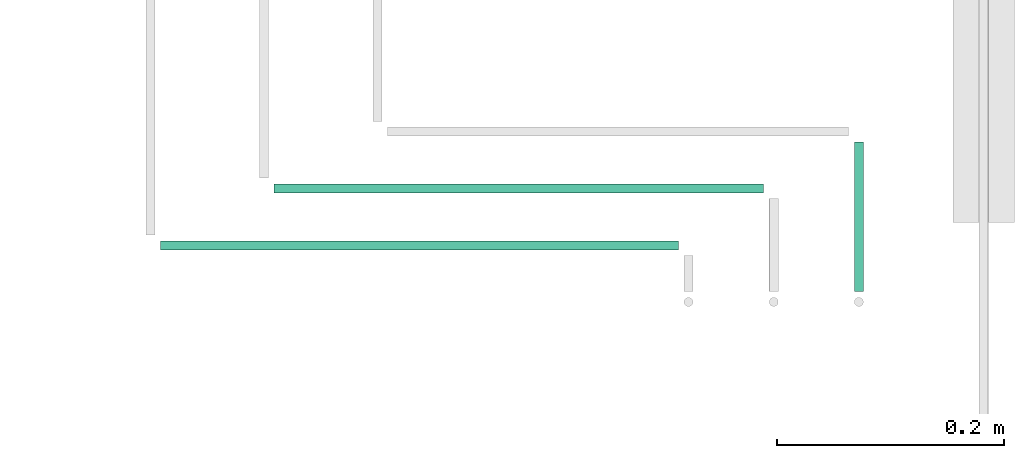
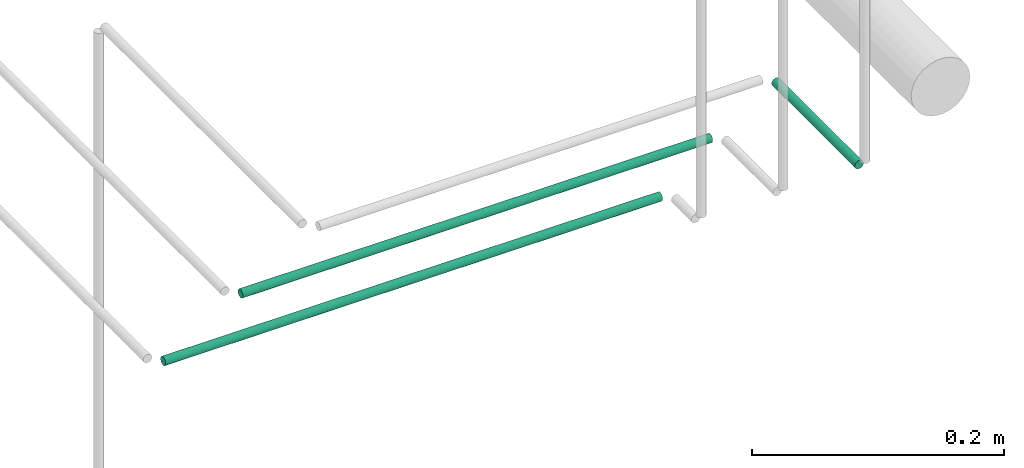
# One storey, part 230 of 331: 3 flow segments.
"""IFC2X3 building model written with IfcOpenShell, lengths in millimetres."""

from ifc_helpers import new_model, entity, si_unit, converted_unit, derived_unit, direction, frame, origin, origin_2d_with_axis, place, context, subcontext, project, spatial, circle, extrude, type_object, element, save


model = new_model("IFC2X3")

# Units and contexts
model_context = context("Model", 3, precision=0.01, world=origin(), true_north=direction((6.12303176911189e-17, 1.0)))
body_context = subcontext(model_context, "Body", "Model", "MODEL_VIEW")
ifc_project = project(units=[si_unit("LENGTHUNIT", "METRE", prefix="MILLI"), si_unit("AREAUNIT", "SQUARE_METRE"), si_unit("VOLUMEUNIT", "CUBIC_METRE"), converted_unit("PLANEANGLEUNIT", "DEGREE", entity("IfcRatioMeasure", 0.0174532925199433), si_unit("PLANEANGLEUNIT", "RADIAN"), dimensions=[0, 0, 0, 0, 0, 0, 0]), si_unit("MASSUNIT", "GRAM", prefix="KILO"), derived_unit("MASSDENSITYUNIT", [(si_unit("MASSUNIT", "GRAM", prefix="KILO"), 1), (si_unit("LENGTHUNIT", "METRE"), -3)]), derived_unit("MOMENTOFINERTIAUNIT", [(si_unit("LENGTHUNIT", "METRE"), 4)]), si_unit("TIMEUNIT", "SECOND"), si_unit("FREQUENCYUNIT", "HERTZ"), si_unit("THERMODYNAMICTEMPERATUREUNIT", "DEGREE_CELSIUS"), derived_unit("THERMALTRANSMITTANCEUNIT", [(si_unit("MASSUNIT", "GRAM", prefix="KILO"), 1), (si_unit("THERMODYNAMICTEMPERATUREUNIT", "KELVIN"), -1), (si_unit("TIMEUNIT", "SECOND"), -3)]), derived_unit("VOLUMETRICFLOWRATEUNIT", [(si_unit("LENGTHUNIT", "METRE"), 3), (si_unit("TIMEUNIT", "SECOND"), -1)]), derived_unit("MASSFLOWRATEUNIT", [(si_unit("MASSUNIT", "GRAM", prefix="KILO"), 1), (si_unit("TIMEUNIT", "SECOND"), -1)]), derived_unit("ROTATIONALFREQUENCYUNIT", [(si_unit("TIMEUNIT", "SECOND"), -1)]), si_unit("ELECTRICCURRENTUNIT", "AMPERE"), si_unit("ELECTRICVOLTAGEUNIT", "VOLT"), si_unit("POWERUNIT", "WATT"), si_unit("FORCEUNIT", "NEWTON", prefix="KILO"), si_unit("ILLUMINANCEUNIT", "LUX"), si_unit("LUMINOUSFLUXUNIT", "LUMEN"), si_unit("LUMINOUSINTENSITYUNIT", "CANDELA"), derived_unit("USERDEFINED", [(si_unit("MASSUNIT", "GRAM", prefix="KILO"), -1), (si_unit("LENGTHUNIT", "METRE"), -2), (si_unit("TIMEUNIT", "SECOND"), 3), (si_unit("LUMINOUSFLUXUNIT", "LUMEN"), 1)]), derived_unit("LINEARVELOCITYUNIT", [(si_unit("LENGTHUNIT", "METRE"), 1), (si_unit("TIMEUNIT", "SECOND"), -1)]), si_unit("PRESSUREUNIT", "PASCAL"), derived_unit("USERDEFINED", [(si_unit("LENGTHUNIT", "METRE"), -2), (si_unit("MASSUNIT", "GRAM", prefix="KILO"), 1), (si_unit("TIMEUNIT", "SECOND"), -2)]), derived_unit("LINEARFORCEUNIT", [(si_unit("MASSUNIT", "GRAM", prefix="KILO"), 1), (si_unit("LENGTHUNIT", "METRE"), 1), (si_unit("TIMEUNIT", "SECOND"), -2), (si_unit("LENGTHUNIT", "METRE"), -1)]), derived_unit("PLANARFORCEUNIT", [(si_unit("MASSUNIT", "GRAM", prefix="KILO"), 1), (si_unit("LENGTHUNIT", "METRE"), 1), (si_unit("TIMEUNIT", "SECOND"), -2), (si_unit("LENGTHUNIT", "METRE"), -2)])], contexts=[model_context])

# Site, building, storey
site_placement = place(None, frame((0.0, -0.00077364408347762, 0.0)))
site = spatial("IfcSite", under=ifc_project, at=site_placement, CompositionType="ELEMENT")
building_placement = place(site_placement, origin())
building = spatial("IfcBuilding", under=site, at=building_placement, CompositionType="ELEMENT")
storey_placement = place(building_placement, origin())
storey = spatial("IfcBuildingStorey", under=building, at=storey_placement, CompositionType="ELEMENT", Elevation=0.0)

# Flow segments
pipe_segment_type = type_object("IfcPipeSegmentType", PredefinedType="NOTDEFINED")
flow_segment_1_placement = place(storey_placement, frame((64969.5166110417, 7674.14924977608, 18444.4047277641)))
element("IfcFlowSegment", 1, at=flow_segment_1_placement, inside=storey, type_object=pipe_segment_type, context=body_context, shape_type="SweptSolid", body=[
    extrude(circle(Radius=4.0, at=origin_2d_with_axis()), frame((5.59527223591499, 0.0, 5.59527223591499), z_axis=(0.0, 1.0, 0.0), x_axis=(-1.0, 0.0, 0.0)), (0.0, 0.0, 1.0), 132.000000000013),
])
flow_segment_2_placement = place(storey_placement, frame((64460.1118832776, 7759.55397754015, 18444.4047277641)))
element("IfcFlowSegment", 2, at=flow_segment_2_placement, inside=storey, type_object=pipe_segment_type, context=body_context, shape_type="SweptSolid", body=[
    extrude(circle(Radius=4.0, at=origin_2d_with_axis()), frame((0.0, 5.59527223591607, 5.59527223591499), z_axis=(1.0, 0.0, 0.0), x_axis=(0.0, -1.0, 0.0)), (0.0, 0.0, 1.0), 431.000000000023),
])
flow_segment_3_placement = place(storey_placement, frame((64360.1118832776, 7709.31407264184, 18444.4047277641)))
element("IfcFlowSegment", 3, at=flow_segment_3_placement, inside=storey, type_object=pipe_segment_type, context=body_context, shape_type="SweptSolid", body=[
    extrude(circle(Radius=4.0, at=origin_2d_with_axis()), frame((0.0, 5.59527223591607, 5.59527223591499), z_axis=(1.0, 0.0, 0.0), x_axis=(0.0, -1.0, 0.0)), (0.0, 0.0, 1.0), 456.000000000026),
])

save(model, "model.ifc")
